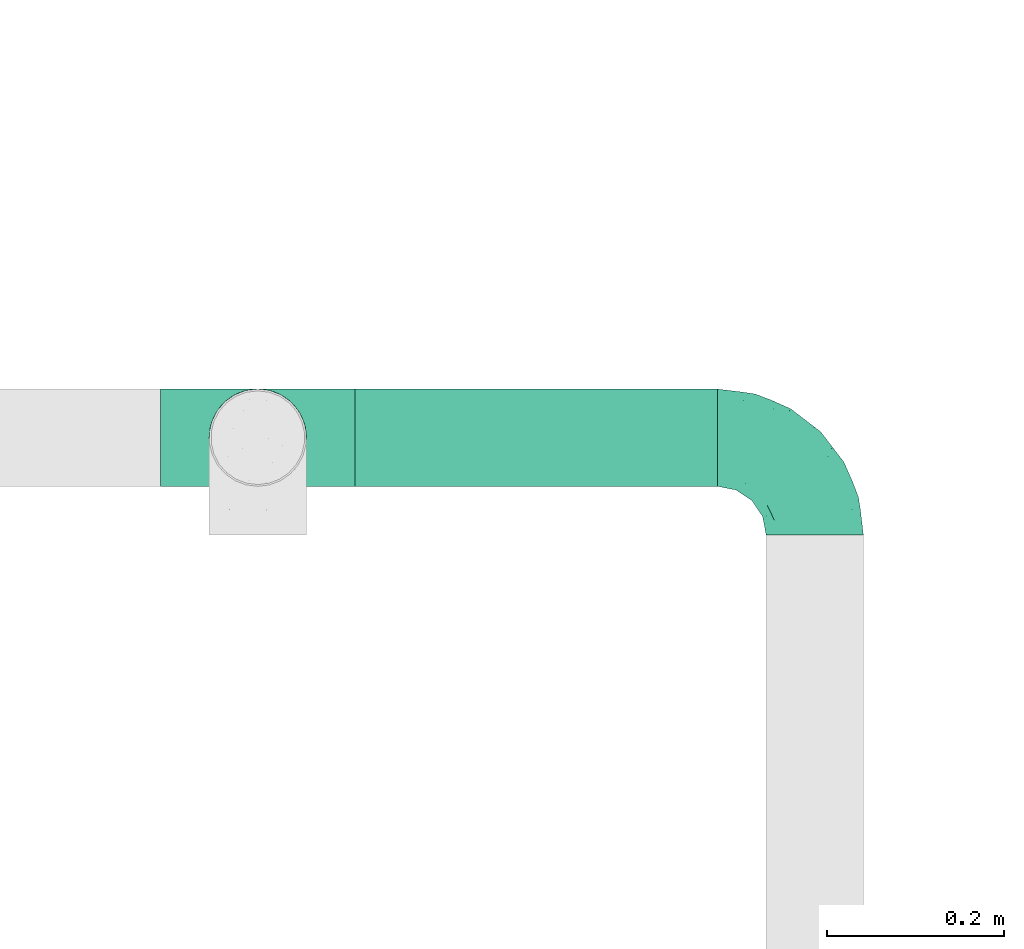
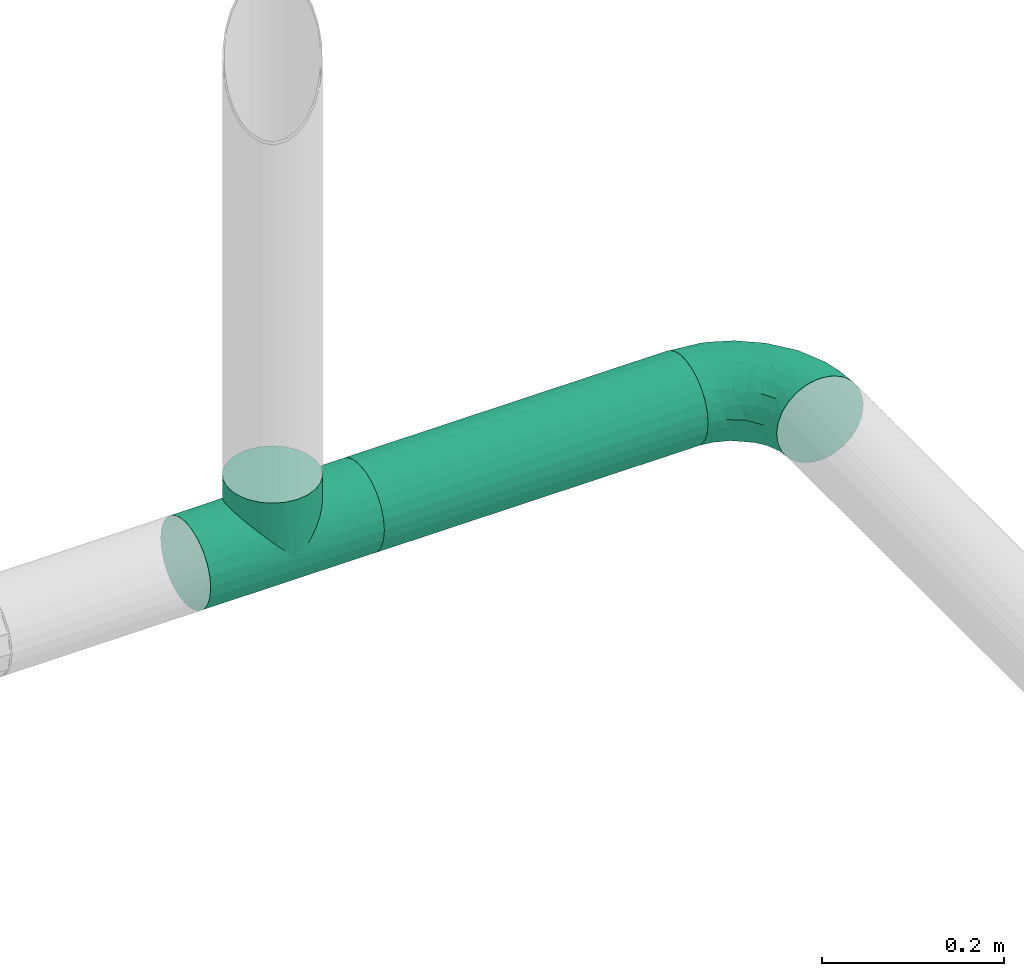
# One storey, part 42 of 103: 2 flow fittings, 1 flow segment.
"""IFC2X3 building model written with IfcOpenShell, lengths in millimetres."""

from ifc_helpers import new_model, entity, si_unit, converted_unit, derived_unit, direction, frame, origin_with_axes, origin_2d_with_axis, place, context, subcontext, project, spatial, hollow_circle, extrude, open_shell, surface_model, source, transform, mapped, material, layer, layer_set, layer_usage, type_object, element, save


model = new_model("IFC2X3")

# Units and contexts
model_context = context("Model", 3, precision=1e-05, world=origin_with_axes(), true_north=direction((0.0, 1.0)))
body_context = subcontext(model_context, "Body", "Model", "MODEL_VIEW")
ifc_project = project(units=[si_unit("AREAUNIT", "SQUARE_METRE"), si_unit("VOLUMEUNIT", "CUBIC_METRE", prefix="DECI"), si_unit("TIMEUNIT", "SECOND"), si_unit("THERMODYNAMICTEMPERATUREUNIT", "DEGREE_CELSIUS"), si_unit("PRESSUREUNIT", "PASCAL"), si_unit("MASSUNIT", "GRAM", prefix="KILO"), si_unit("LENGTHUNIT", "METRE", prefix="MILLI"), si_unit("POWERUNIT", "WATT"), si_unit("ELECTRICCURRENTUNIT", "AMPERE"), si_unit("ELECTRICVOLTAGEUNIT", "VOLT"), derived_unit("VOLUMETRICFLOWRATEUNIT", [(si_unit("VOLUMEUNIT", "CUBIC_METRE", prefix="DECI"), 1), (si_unit("TIMEUNIT", "SECOND"), -1)]), derived_unit("LINEARVELOCITYUNIT", [(si_unit("LENGTHUNIT", "METRE"), 1), (si_unit("TIMEUNIT", "SECOND"), -1)]), derived_unit("MASSDENSITYUNIT", [(si_unit("MASSUNIT", "GRAM", prefix="KILO"), 1), (si_unit("VOLUMEUNIT", "CUBIC_METRE"), -1)]), converted_unit("PLANEANGLEUNIT", "DEGREE", entity("IfcRatioMeasure", 0.01745), si_unit("PLANEANGLEUNIT", "RADIAN"), dimensions=[0, 0, 0, 0, 0, 0, 0])], contexts=[model_context])

# Site, building, storey
site_placement = place(None, origin_with_axes())
site = spatial("IfcSite", under=ifc_project, at=site_placement, CompositionType="ELEMENT")
building_placement = place(site_placement, origin_with_axes())
building = spatial("IfcBuilding", under=site, at=building_placement, Name="mc-building", CompositionType="ELEMENT")
storey_placement = place(building_placement, frame((0.0, 0.0, 5900.0), z_axis=(0.0, 0.0, 1.0), x_axis=(1.0, 0.0, 0.0)))
storey = spatial("IfcBuildingStorey", under=building, at=storey_placement, Name="3. Korrus", CompositionType="ELEMENT", Elevation=5900.0)

# Flow fittings
duct_fitting_type_1 = type_object("IfcDuctFittingType", PredefinedType="JUNCTION")
shared_shape_1 = source(origin_with_axes(), body_context, "Body", "SurfaceModel", [
    surface_model("IfcShellBasedSurfaceModel", [(0.0, -80.0, -55.0), (14.23505, -80.0, -53.12592), (-14.23505, -80.0, -53.12592), (-53.12592, -80.0, 14.23505), (-27.5, -80.0, -47.63139), (-47.63139, -80.0, -27.5), (-38.89087, -80.0, -38.89087), (55.0, -80.0, 0.0), (53.12592, -80.0, 14.23505), (38.89087, -80.0, -38.89087), (27.5, -80.0, -47.63139), (53.12592, -80.0, -14.23505), (47.63139, -80.0, -27.5), (-53.12592, -80.0, -14.23505), (-47.63139, -80.0, 27.5), (-38.89087, -80.0, 38.89087), (14.23505, -80.0, 53.12592), (-27.5, -80.0, 47.63139), (-14.23505, -80.0, 53.12592), (47.63139, -80.0, 27.5), (38.89087, -80.0, 38.89087), (27.5, -80.0, 47.63139), (0.0, -80.0, 55.0), (-55.0, -80.0, 0.0), (0.0, 0.0, 55.0), (-7.4066, -7.4066, 54.49901), (-14.74521, -14.74521, 52.98659), (-21.93978, -21.93978, 50.43457), (-28.89905, -28.89905, 46.79578), (-35.50357, -35.50357, 42.00591), (-41.58668, -41.58668, 35.99373), (-46.92319, -46.92319, 28.69171), (-51.19777, -51.19777, 20.0945), (-50.37866, -80.0, 20.86752), (-54.01174, -54.01174, 10.37938), (-55.0, -55.0, 0.0), (-54.06296, -80.0, 7.11752), (-54.01174, -54.01174, -10.37938), (-51.19777, -51.19777, -20.0945), (-54.06296, -80.0, -7.11752), (-46.92319, -46.92319, -28.69171), (-41.58668, -41.58668, -35.99373), (-50.37866, -80.0, -20.86752), (-35.50357, -35.50357, -42.00591), (-21.93978, -21.93978, -50.43457), (-14.74521, -14.74521, -52.98659), (-7.4066, -7.4066, -54.49901), (0.0, 0.0, -55.0), (-28.89905, -28.89905, -46.79578), (7.4066, -7.4066, -54.49901), (14.74521, -14.74521, -52.98659), (21.93978, -21.93978, -50.43457), (28.89905, -28.89905, -46.79578), (35.50357, -35.50357, -42.00591), (41.58668, -41.58668, -35.99373), (46.92319, -46.92319, -28.69171), (51.19777, -51.19777, -20.0945), (50.37866, -80.0, -20.86752), (54.01174, -54.01174, -10.37938), (55.0, -55.0, 0.0), (54.06296, -80.0, -7.11752), (54.01174, -54.01174, 10.37938), (51.19777, -51.19777, 20.0945), (54.06296, -80.0, 7.11752), (46.92319, -46.92319, 28.69171), (41.58668, -41.58668, 35.99373), (50.37866, -80.0, 20.86752), (35.50357, -35.50357, 42.00591), (21.93978, -21.93978, 50.43457), (14.74521, -14.74521, 52.98659), (7.4066, -7.4066, 54.49901), (28.89905, -28.89905, 46.79578), (-110.0, 0.0, -55.0), (-110.0, -14.23505, -53.12592), (-110.0, 14.23505, -53.12592), (-110.0, 53.12592, 14.23505), (-110.0, 27.5, -47.63139), (-110.0, 47.63139, -27.5), (-110.0, 38.89087, -38.89087), (-110.0, -55.0, 0.0), (-110.0, -53.12592, 14.23505), (-110.0, -38.89087, -38.89087), (-110.0, -27.5, -47.63139), (-110.0, -53.12592, -14.23505), (-110.0, -47.63139, -27.5), (-110.0, 53.12592, -14.23505), (-110.0, 47.63139, 27.5), (-110.0, 38.89087, 38.89087), (-110.0, -14.23505, 53.12592), (-110.0, 27.5, 47.63139), (-110.0, 14.23505, 53.12592), (-110.0, -47.63139, 27.5), (-110.0, -38.89087, 38.89087), (-110.0, -27.5, 47.63139), (-110.0, 0.0, 55.0), (-110.0, 55.0, 0.0), (110.0, 55.0, 0.0), (110.0, 0.0, -55.0), (110.0, 14.23505, -53.12592), (110.0, 27.5, -47.63139), (110.0, 38.89087, -38.89087), (110.0, 47.63139, -27.5), (110.0, -38.89087, -38.89087), (110.0, -53.12592, 14.23505), (110.0, -27.5, -47.63139), (110.0, -14.23505, -53.12592), (110.0, -47.63139, -27.5), (110.0, -53.12592, -14.23505), (110.0, -55.0, 0.0), (110.0, 53.12592, -14.23505), (110.0, 53.12592, 14.23505), (110.0, 47.63139, 27.5), (110.0, 38.89087, 38.89087), (110.0, 0.0, 55.0), (110.0, 27.5, 47.63139), (110.0, 14.23505, 53.12592), (110.0, -47.63139, 27.5), (110.0, -38.89087, 38.89087), (110.0, -27.5, 47.63139), (110.0, -14.23505, 53.12592)], [open_shell([[[0, 1, 2]], [[2, 3, 4]], [[5, 6, 3]], [[6, 4, 3]], [[2, 7, 8]], [[9, 7, 10]], [[1, 10, 7]], [[11, 7, 12]], [[9, 12, 7]], [[7, 2, 1]], [[5, 3, 13]], [[2, 14, 3]], [[2, 15, 14]], [[2, 16, 17]], [[17, 15, 2]], [[16, 18, 17]], [[2, 8, 19]], [[2, 19, 20]], [[2, 20, 21]], [[16, 2, 21]], [[16, 22, 18]], [[23, 13, 3]], [[24, 25, 22]], [[26, 27, 18]], [[25, 26, 18]], [[22, 25, 18]], [[17, 28, 29]], [[17, 18, 27]], [[17, 29, 15]], [[28, 17, 27]], [[30, 31, 14]], [[32, 3, 33]], [[32, 34, 3]], [[35, 36, 34]], [[31, 32, 14]], [[15, 30, 14]], [[34, 36, 3]], [[33, 14, 32]], [[36, 35, 23]], [[30, 15, 29]], [[37, 38, 13]], [[37, 13, 39]], [[40, 41, 5]], [[38, 5, 42]], [[38, 40, 5]], [[37, 39, 35]], [[35, 39, 23]], [[13, 38, 42]], [[41, 6, 5]], [[41, 43, 6]], [[44, 45, 2]], [[46, 47, 0]], [[45, 46, 2]], [[43, 48, 4]], [[44, 4, 48]], [[44, 2, 4]], [[46, 0, 2]], [[43, 4, 6]], [[47, 49, 0]], [[50, 51, 1]], [[49, 50, 1]], [[0, 49, 1]], [[10, 52, 53]], [[10, 1, 51]], [[10, 53, 9]], [[52, 10, 51]], [[54, 55, 12]], [[56, 11, 57]], [[56, 58, 11]], [[59, 60, 58]], [[55, 56, 12]], [[9, 54, 12]], [[58, 60, 11]], [[57, 12, 56]], [[60, 59, 7]], [[54, 9, 53]], [[61, 62, 8]], [[61, 8, 63]], [[64, 65, 19]], [[62, 19, 66]], [[62, 64, 19]], [[61, 63, 59]], [[7, 59, 63]], [[62, 66, 8]], [[65, 20, 19]], [[65, 67, 20]], [[68, 69, 16]], [[70, 24, 22]], [[69, 70, 16]], [[67, 71, 21]], [[68, 21, 71]], [[68, 16, 21]], [[70, 22, 16]], [[67, 21, 20]], [[72, 73, 74]], [[74, 75, 76]], [[77, 78, 75]], [[76, 75, 78]], [[74, 79, 80]], [[81, 79, 82]], [[73, 82, 79]], [[83, 79, 84]], [[81, 84, 79]], [[79, 74, 73]], [[77, 75, 85]], [[74, 86, 75]], [[74, 87, 86]], [[74, 88, 89]], [[89, 87, 74]], [[88, 90, 89]], [[74, 91, 92]], [[91, 74, 80]], [[92, 93, 74]], [[74, 93, 88]], [[88, 94, 90]], [[95, 85, 75]], [[96, 97, 98]], [[99, 96, 98]], [[96, 100, 101]], [[100, 96, 99]], [[102, 97, 103]], [[97, 102, 104]], [[104, 105, 97]], [[102, 103, 106]], [[106, 103, 107]], [[108, 107, 103]], [[109, 96, 101]], [[110, 111, 97]], [[97, 111, 112]], [[113, 97, 114]], [[97, 112, 114]], [[113, 114, 115]], [[116, 103, 97]], [[117, 116, 97]], [[118, 117, 97]], [[119, 118, 97]], [[119, 97, 113]], [[96, 110, 97]], [[24, 113, 115]], [[89, 115, 114]], [[94, 24, 90]], [[90, 24, 115]], [[115, 89, 90]], [[114, 87, 89]], [[86, 112, 111]], [[75, 111, 110]], [[95, 110, 96]], [[87, 112, 86]], [[86, 111, 75]], [[110, 95, 75]], [[112, 87, 114]], [[85, 96, 109]], [[77, 109, 101]], [[95, 96, 85]], [[85, 109, 77]], [[101, 78, 77]], [[101, 100, 78]], [[76, 100, 99]], [[74, 99, 98]], [[47, 98, 97]], [[76, 99, 74]], [[47, 72, 74]], [[98, 47, 74]], [[100, 76, 78]], [[47, 46, 72]], [[45, 44, 73]], [[46, 45, 73]], [[72, 46, 73]], [[82, 48, 43]], [[82, 73, 44]], [[82, 43, 81]], [[48, 82, 44]], [[41, 40, 84]], [[38, 37, 83]], [[40, 38, 84]], [[81, 41, 84]], [[37, 79, 83]], [[83, 84, 38]], [[79, 37, 35]], [[41, 81, 43]], [[49, 97, 105]], [[105, 104, 51]], [[53, 104, 102]], [[53, 52, 104]], [[49, 47, 97]], [[51, 50, 105]], [[52, 51, 104]], [[49, 105, 50]], [[54, 102, 106]], [[56, 106, 107]], [[58, 107, 108]], [[55, 54, 106]], [[58, 56, 107]], [[59, 58, 108]], [[55, 106, 56]], [[102, 54, 53]], [[34, 32, 80]], [[31, 30, 91]], [[32, 31, 91]], [[35, 34, 79]], [[80, 79, 34]], [[32, 91, 80]], [[30, 92, 91]], [[30, 29, 92]], [[27, 26, 88]], [[25, 24, 94]], [[26, 25, 88]], [[29, 28, 93]], [[27, 93, 28]], [[27, 88, 93]], [[25, 94, 88]], [[29, 93, 92]], [[61, 108, 103]], [[62, 103, 116]], [[65, 116, 117]], [[61, 59, 108]], [[64, 62, 116]], [[65, 64, 116]], [[61, 103, 62]], [[117, 67, 65]], [[71, 67, 118]], [[118, 67, 117]], [[68, 118, 119]], [[70, 119, 113]], [[68, 71, 118]], [[70, 69, 119]], [[24, 70, 113]], [[68, 119, 69]]])]),
])
flow_fitting_1_placement = place(storey_placement, frame((10809.16476, 9477.62755, 2345.0), z_axis=(0.0, 1.0, 0.0), x_axis=(1.0, 0.0, 0.0)))
element("IfcFlowFitting", 1, at=flow_fitting_1_placement, inside=storey, type_object=duct_fitting_type_1, context=body_context, shape_type="MappedRepresentation", body=[
    mapped(shared_shape_1, transform((0.0, 0.0, 0.0), scale=1.0)),
])
duct_fitting_type_2 = type_object("IfcDuctFittingType", Name="BU", PredefinedType="BEND")
shared_shape_2 = source(origin_with_axes(), body_context, "Body", "SurfaceModel", [
    surface_model("IfcShellBasedSurfaceModel", [(-110.0, 0.0, -55.0), (-110.0, -14.23505, -53.12592), (-110.0, 14.23505, -53.12592), (-110.0, 53.12592, 14.23505), (-110.0, 27.5, -47.63139), (-110.0, 38.89087, -38.89087), (-110.0, -55.0, 0.0), (-110.0, -53.12592, 14.23505), (-110.0, -38.89087, -38.89087), (-110.0, -27.5, -47.63139), (-110.0, -53.12592, -14.23505), (-110.0, -47.63139, -27.5), (-110.0, -14.23505, 53.12592), (-110.0, 14.23505, 53.12592), (-110.0, 27.5, 47.63139), (-110.0, -47.63139, 27.5), (-110.0, -38.89087, 38.89087), (-110.0, -27.5, 47.63139), (-110.0, 0.0, 55.0), (-110.0, 55.0, 0.0), (-110.0, 53.12592, -14.23505), (-110.0, 47.63139, -27.5), (-110.0, 47.63139, 27.5), (-110.0, 38.89087, 38.89087), (-14.23505, 110.0, -53.12592), (-55.0, 110.0, 0.0), (0.0, 110.0, -55.0), (-27.5, 110.0, -47.63139), (-38.89087, 110.0, -38.89087), (-47.63139, 110.0, -27.5), (38.89087, 110.0, -38.89087), (53.12592, 110.0, 14.23505), (27.5, 110.0, -47.63139), (14.23505, 110.0, -53.12592), (47.63139, 110.0, -27.5), (53.12592, 110.0, -14.23505), (55.0, 110.0, 0.0), (-53.12592, 110.0, -14.23505), (-53.12592, 110.0, 14.23505), (-47.63139, 110.0, 27.5), (-38.89087, 110.0, 38.89087), (-27.5, 110.0, 47.63139), (0.0, 110.0, 55.0), (-14.23505, 110.0, 53.12592), (38.89087, 110.0, 38.89087), (47.63139, 110.0, 27.5), (27.5, 110.0, 47.63139), (14.23505, 110.0, 53.12592), (-64.21732, 48.68956, 43.63444), (-76.6405, 38.18013, 45.55988), (-60.44912, 32.56953, 51.94617), (-76.00813, 5.38378, 55.0), (-90.15553, 11.94394, 54.09138), (-78.5998, 26.77405, 50.81338), (-70.18771, 18.55163, 54.03432), (-75.55424, 54.2118, 32.41257), (-93.27622, 45.77614, 33.48188), (-96.12334, 22.13664, 50.81337), (-21.00813, 45.34362, 55.0), (-18.36258, 70.48427, 54.04484), (-32.04182, 59.64019, 52.24446), (-63.88653, 74.77858, 17.99134), (-74.66383, 63.08407, 19.92123), (-63.60674, 66.07878, 29.97482), (-99.597, 52.72185, 18.52927), (-93.11138, 56.59448, 10.50359), (-98.21577, 57.34403, 0.0), (-53.42855, 92.60092, 21.04759), (-88.54852, 54.8376, 21.04759), (-11.86161, 90.23965, 54.10313), (-5.38378, 76.00813, 55.0), (-57.34403, 98.21577, 0.0), (-56.64619, 93.12774, 10.22088), (-45.34362, 21.00813, 55.0), (-44.60838, 44.60838, 52.13415), (-92.68484, 35.46673, 43.63443), (-22.25266, 95.40765, 50.81337), (-35.97783, 90.61597, 43.63443), (-43.70931, 69.58671, 44.47149), (-27.23711, 77.39884, 50.81337), (-57.2828, 79.3123, 24.9774), (-58.67786, 84.31125, 16.04456), (-82.93277, 60.36161, 12.91784), (-49.88337, 54.51816, 47.224), (-74.57753, 66.83759, 9.55742), (-45.35812, 94.97281, 33.48188), (-59.18663, 88.95241, 0.0), (-51.517, 78.6292, 33.48188), (-65.14788, 80.03077, 0.0), (-56.45322, 62.06476, 39.63545), (-88.95241, 59.18663, 0.0), (-71.10913, 71.10913, 0.0), (-80.03077, 65.14788, 0.0), (-94.9309, 45.36788, -33.48188), (-93.11358, 56.60141, -10.46614), (-99.64997, 52.79499, -18.30015), (-90.20425, 36.08686, -43.63443), (-79.99933, 46.56772, -37.92748), (-76.00813, 5.38378, -55.0), (-72.75364, 19.68651, -53.60527), (-45.34362, 21.00813, -55.0), (-21.91957, 65.12078, -53.85897), (-5.38378, 76.00813, -55.0), (-21.00813, 45.34362, -55.0), (-35.41876, 92.89265, -43.63443), (-91.10309, 11.02766, -54.21832), (-45.77614, 93.27622, -33.48188), (-90.50474, 23.21022, -50.81337), (-70.92854, 33.31794, -49.51754), (-78.52933, 63.35627, -11.73997), (-24.91508, 84.05606, -50.81337), (-88.78941, 54.74452, -21.04759), (-69.59921, 57.34866, -33.48187), (-73.36422, 62.46673, -22.94182), (-63.49062, 67.59111, -28.46929), (-56.59448, 93.11138, -10.50359), (-54.8376, 88.54852, -21.04759), (-54.10679, 75.85581, -32.31867), (-57.75956, 31.09612, -52.80882), (-52.72185, 99.597, -18.52927), (-12.62913, 89.46304, -53.99097), (-34.46825, 66.46123, -50.04329), (-43.9837, 43.9837, -52.42279), (-65.78527, 72.58348, -17.68796), (-70.34468, 43.65295, -44.21951), (-57.47001, 51.99467, -44.91465), (-60.72547, 82.29174, -12.88567), (-42.34915, 74.24548, -43.63444), (-57.25194, 63.5016, -38.08211), (-80.95344, 53.56991, -29.32027), (-52.32891, 4.55257, -54.0482), (32.52942, 47.13398, -30.48571), (14.88266, 20.92917, -33.7947), (14.95561, 36.05775, -42.26543), (30.24048, 70.09027, -41.7461), (19.3559, 65.35825, -48.00507), (-70.35075, -46.44478, -19.5952), (-47.13398, -32.52942, -30.48571), (-28.49299, -30.5778, -16.4009), (-4.55257, 52.32891, -54.0482), (-22.4954, 22.4954, -53.25347), (-75.47368, -11.22546, -52.60718), (-81.32209, -51.5606, -9.98467), (-80.81763, -41.84862, -32.14655), (-70.09027, -30.24048, -41.7461), (-36.05774, -14.95561, -42.26543), (-9.15831, -10.852, -27.8997), (-65.35825, -19.3559, -48.00507), (11.22546, 75.47368, -52.60718), (3.94376, 43.9333, -50.53315), (-13.39742, 13.39743, -48.13058), (-43.9333, -3.94376, -50.53315), (49.37776, 67.29486, 0.0), (41.8609, 47.82256, -9.92641), (50.20582, 74.51695, -9.9731), (18.93131, 11.7156, -17.56239), (-27.5, -32.89419, 0.0), (-1.23348, -12.25375, -12.18106), (41.84862, 80.81763, -32.14655), (35.70604, 41.31408, -20.38235), (46.44478, 70.35075, -19.5952), (32.89419, 27.5, 0.0), (6.67262, -6.67262, 0.0), (-67.29486, -49.37776, 0.0), (-50.36265, -42.95545, -9.51562), (-5.47251, 5.47251, -39.92906), (-70.35075, -46.44478, 19.5952), (-74.51695, -50.20582, 9.9731), (-41.31407, -35.70604, 20.38235), (-47.13398, -32.52942, 30.48571), (-80.81763, -41.84862, 32.14655), (-4.55257, 52.32891, 54.0482), (11.22546, 75.47368, 52.60718), (-43.9333, -3.94376, 50.53315), (-65.35825, -19.3559, 48.00507), (-36.05774, -14.95561, 42.26543), (-70.09027, -30.24048, 41.7461), (-11.7156, -18.93131, 17.56239), (30.5778, 28.49299, 16.4009), (12.25375, 1.23348, 12.18106), (51.5606, 81.32209, 9.98467), (42.95545, 50.36265, 9.51562), (-75.47368, -11.22546, 52.60718), (-52.32891, 4.55257, 54.0482), (3.94376, 43.9333, 50.53315), (-22.4954, 22.4954, 53.25347), (-13.39742, 13.39743, 48.13058), (10.852, 9.15831, 27.8997), (-20.92916, -14.88266, 33.79469), (-47.82256, -41.8609, 9.92641), (32.52942, 47.13398, 30.48571), (46.44478, 70.35075, 19.5952), (41.84862, 80.81763, 32.14655), (30.24048, 70.09027, 41.7461), (19.3559, 65.35825, 48.00507), (14.95561, 36.05775, 42.26543), (-5.47251, 5.47251, 39.92906)], [open_shell([[[0, 1, 2]], [[2, 3, 4]], [[4, 3, 5]], [[2, 6, 7]], [[8, 6, 9]], [[1, 9, 6]], [[10, 6, 11]], [[8, 11, 6]], [[6, 2, 1]], [[12, 13, 14]], [[15, 2, 7]], [[16, 17, 2]], [[2, 17, 12]], [[12, 18, 13]], [[19, 20, 3]], [[5, 3, 21]], [[20, 21, 3]], [[22, 3, 2]], [[23, 22, 2]], [[12, 14, 2]], [[2, 14, 23]], [[15, 16, 2]], [[24, 25, 26]], [[27, 25, 24]], [[25, 28, 29]], [[28, 25, 27]], [[30, 26, 31]], [[26, 30, 32]], [[32, 33, 26]], [[34, 31, 35]], [[31, 34, 30]], [[35, 31, 36]], [[29, 37, 25]], [[38, 39, 26]], [[39, 40, 26]], [[41, 42, 40]], [[42, 26, 40]], [[42, 41, 43]], [[26, 44, 45]], [[31, 26, 45]], [[26, 46, 44]], [[47, 46, 26]], [[42, 47, 26]], [[25, 38, 26]], [[48, 49, 50]], [[18, 51, 52]], [[53, 54, 50]], [[55, 56, 49]], [[56, 22, 23]], [[13, 57, 14]], [[58, 59, 60]], [[61, 62, 63]], [[3, 64, 65]], [[53, 52, 54]], [[3, 65, 66]], [[67, 39, 38]], [[56, 68, 64]], [[65, 64, 68]], [[69, 59, 70]], [[38, 71, 72]], [[73, 58, 74]], [[75, 49, 56]], [[76, 69, 43]], [[53, 57, 52]], [[77, 78, 79]], [[41, 76, 43]], [[43, 69, 42]], [[55, 68, 56]], [[23, 14, 75]], [[76, 77, 79]], [[80, 67, 81]], [[62, 82, 68]], [[60, 78, 83]], [[62, 84, 82]], [[85, 77, 40]], [[81, 67, 72]], [[86, 72, 71]], [[87, 85, 67]], [[61, 81, 88]], [[77, 41, 40]], [[78, 77, 87]], [[23, 75, 56]], [[83, 89, 48]], [[85, 40, 39]], [[62, 68, 55]], [[89, 87, 63]], [[83, 48, 50]], [[57, 75, 14]], [[49, 75, 53]], [[67, 85, 39]], [[87, 77, 85]], [[63, 62, 55]], [[89, 55, 48]], [[80, 63, 87]], [[66, 65, 90]], [[66, 19, 3]], [[84, 91, 92]], [[92, 90, 82]], [[65, 82, 90]], [[61, 84, 62]], [[92, 82, 84]], [[68, 82, 65]], [[3, 22, 64]], [[56, 64, 22]], [[38, 25, 71]], [[81, 72, 86]], [[38, 72, 67]], [[91, 61, 88]], [[80, 81, 61]], [[63, 80, 61]], [[67, 80, 87]], [[77, 76, 41]], [[79, 59, 69]], [[79, 69, 76]], [[42, 69, 70]], [[60, 59, 79]], [[58, 70, 59]], [[78, 60, 79]], [[58, 60, 74]], [[52, 57, 13]], [[75, 57, 53]], [[18, 52, 13]], [[52, 51, 54]], [[51, 73, 54]], [[50, 73, 74]], [[73, 50, 54]], [[50, 74, 83]], [[60, 83, 74]], [[89, 83, 78]], [[87, 89, 78]], [[55, 89, 63]], [[50, 49, 53]], [[55, 49, 48]], [[81, 86, 88]], [[91, 84, 61]], [[5, 21, 93]], [[90, 94, 66]], [[20, 94, 95]], [[96, 93, 97]], [[98, 99, 100]], [[96, 4, 5]], [[101, 102, 103]], [[28, 27, 104]], [[2, 105, 0]], [[104, 106, 28]], [[99, 105, 107]], [[108, 107, 96]], [[90, 109, 94]], [[107, 2, 4]], [[20, 66, 94]], [[27, 24, 110]], [[109, 111, 94]], [[112, 113, 114]], [[37, 115, 71]], [[116, 106, 117]], [[99, 118, 100]], [[116, 115, 119]], [[37, 119, 115]], [[24, 120, 110]], [[121, 110, 101]], [[119, 106, 116]], [[101, 110, 120]], [[122, 103, 100]], [[117, 123, 116]], [[124, 125, 108]], [[115, 116, 126]], [[106, 29, 28]], [[26, 102, 120]], [[127, 104, 110]], [[97, 124, 96]], [[125, 122, 118]], [[128, 127, 125]], [[96, 5, 93]], [[115, 126, 86]], [[117, 106, 127]], [[111, 113, 129]], [[95, 93, 21]], [[97, 129, 112]], [[110, 104, 27]], [[106, 104, 127]], [[96, 107, 4]], [[99, 107, 108]], [[99, 108, 118]], [[105, 99, 98]], [[112, 114, 128]], [[121, 125, 127]], [[20, 19, 66]], [[109, 90, 92]], [[94, 111, 95]], [[91, 123, 109]], [[129, 113, 112]], [[93, 95, 111]], [[21, 20, 95]], [[71, 115, 86]], [[71, 25, 37]], [[123, 91, 88]], [[126, 116, 123]], [[123, 88, 126]], [[86, 126, 88]], [[37, 29, 119]], [[106, 119, 29]], [[129, 93, 111]], [[124, 112, 125]], [[0, 105, 98]], [[107, 105, 2]], [[125, 118, 108]], [[100, 118, 122]], [[93, 129, 97]], [[113, 111, 109]], [[109, 123, 113]], [[114, 123, 117]], [[123, 114, 113]], [[128, 114, 117]], [[127, 128, 117]], [[112, 128, 125]], [[103, 122, 101]], [[110, 121, 127]], [[101, 122, 121]], [[125, 121, 122]], [[26, 120, 24]], [[101, 120, 102]], [[96, 124, 108]], [[92, 91, 109]], [[112, 124, 97]], [[100, 130, 98]], [[131, 132, 133]], [[32, 134, 135]], [[136, 137, 138]], [[139, 140, 103]], [[98, 141, 0]], [[142, 10, 136]], [[143, 144, 137]], [[6, 10, 142]], [[137, 145, 146]], [[144, 147, 145]], [[143, 136, 11]], [[11, 136, 10]], [[8, 143, 11]], [[148, 149, 139]], [[8, 9, 144]], [[9, 1, 147]], [[130, 141, 98]], [[103, 140, 100]], [[148, 135, 149]], [[150, 151, 140]], [[152, 153, 154]], [[130, 140, 151]], [[148, 26, 33]], [[147, 1, 141]], [[155, 146, 132]], [[156, 138, 157]], [[134, 30, 158]], [[150, 140, 149]], [[158, 30, 34]], [[30, 134, 32]], [[153, 159, 160]], [[131, 160, 159]], [[144, 145, 137]], [[36, 152, 154]], [[146, 138, 137]], [[155, 161, 162]], [[158, 160, 131]], [[133, 149, 135]], [[156, 163, 164]], [[163, 142, 164]], [[139, 103, 102]], [[153, 152, 161]], [[34, 35, 160]], [[162, 157, 155]], [[132, 165, 133]], [[157, 146, 155]], [[140, 130, 100]], [[141, 130, 151]], [[141, 151, 147]], [[141, 1, 0]], [[102, 26, 148]], [[140, 139, 149]], [[102, 148, 139]], [[135, 33, 32]], [[151, 150, 145]], [[9, 147, 144]], [[151, 145, 147]], [[145, 165, 146]], [[135, 148, 33]], [[133, 135, 134]], [[131, 133, 134]], [[133, 165, 150]], [[133, 150, 149]], [[145, 150, 165]], [[132, 131, 159]], [[146, 165, 132]], [[160, 158, 34]], [[134, 158, 131]], [[144, 143, 8]], [[136, 143, 137]], [[155, 153, 161]], [[154, 153, 160]], [[153, 155, 159]], [[132, 159, 155]], [[160, 35, 154]], [[36, 154, 35]], [[164, 136, 138]], [[6, 142, 163]], [[136, 164, 142]], [[156, 164, 138]], [[156, 157, 162]], [[146, 157, 138]], [[15, 7, 166]], [[6, 163, 167]], [[168, 169, 166]], [[166, 169, 170]], [[171, 172, 70]], [[173, 174, 175]], [[17, 176, 174]], [[177, 156, 162]], [[176, 16, 170]], [[170, 16, 15]], [[161, 178, 179]], [[152, 180, 181]], [[182, 173, 183]], [[18, 12, 182]], [[184, 185, 186]], [[183, 185, 73]], [[183, 73, 51]], [[177, 187, 188]], [[189, 168, 166]], [[187, 178, 190]], [[16, 176, 17]], [[161, 152, 181]], [[45, 191, 31]], [[45, 44, 192]], [[192, 191, 45]], [[180, 36, 31]], [[193, 194, 195]], [[46, 47, 194]], [[193, 195, 190]], [[193, 44, 46]], [[172, 42, 70]], [[185, 58, 73]], [[189, 163, 156]], [[163, 189, 167]], [[70, 58, 171]], [[184, 171, 185]], [[169, 188, 175]], [[180, 31, 191]], [[192, 193, 190]], [[191, 190, 178]], [[182, 174, 173]], [[194, 47, 172]], [[190, 195, 187]], [[186, 185, 173]], [[162, 179, 177]], [[188, 196, 175]], [[179, 187, 177]], [[185, 171, 58]], [[172, 171, 184]], [[172, 184, 194]], [[172, 47, 42]], [[51, 18, 182]], [[185, 183, 173]], [[51, 182, 183]], [[174, 12, 17]], [[184, 186, 195]], [[46, 194, 193]], [[184, 195, 194]], [[195, 196, 187]], [[174, 182, 12]], [[175, 174, 176]], [[169, 175, 176]], [[175, 196, 186]], [[175, 186, 173]], [[195, 186, 196]], [[188, 169, 168]], [[187, 196, 188]], [[166, 170, 15]], [[176, 170, 169]], [[193, 192, 44]], [[191, 192, 190]], [[177, 189, 156]], [[167, 189, 166]], [[189, 177, 168]], [[188, 168, 177]], [[166, 7, 167]], [[6, 167, 7]], [[181, 191, 178]], [[36, 180, 152]], [[191, 181, 180]], [[161, 181, 178]], [[161, 179, 162]], [[187, 179, 178]]])]),
])
flow_fitting_2_placement = place(storey_placement, frame((11439.21808, 9477.62755, 2345.0), z_axis=(0.0, 0.0, 1.0), x_axis=(0.0, 1.0, 0.0)))
element("IfcFlowFitting", 2, at=flow_fitting_2_placement, inside=storey, type_object=duct_fitting_type_2, Name="BU", context=body_context, shape_type="MappedRepresentation", body=[
    mapped(shared_shape_2, transform((0.0, 0.0, 0.0), scale=1.0)),
])

# Flow segment
ifc_material = material(Name="FZ1")
ifc_layer = layer(ifc_material, 0.0)
ifc_layer_set = layer_set([ifc_layer], Name="FZ1")
ifc_layer_usage = layer_usage(ifc_layer_set, "AXIS1", "POSITIVE", 0.0)
duct_segment_type = type_object("IfcDuctSegmentType", PredefinedType="RIGIDSEGMENT")
shared_shape_3 = source(origin_with_axes(), body_context, "Body", "SweptSolid", [
    extrude(hollow_circle(Radius=55.0, WallThickness=2.0, at=origin_2d_with_axis()), frame((0.0, 0.0, 0.0), z_axis=(1.0, 0.0, 0.0), x_axis=(0.0, 1.0, 0.0)), (0.0, 0.0, 1.0), 410.1),
])
flow_segment_placement = place(storey_placement, frame((11329.21808, 9477.62755, 2345.0), z_axis=(0.0, 0.0, 1.0), x_axis=(-1.0, 0.0, 0.0)))
element("IfcFlowSegment", 3, at=flow_segment_placement, inside=storey, type_object=duct_segment_type, material=ifc_layer_usage, context=body_context, shape_type="MappedRepresentation", body=[
    mapped(shared_shape_3, transform((0.0, 0.0, 0.0), scale=1.0)),
])

save(model, "model.ifc")
